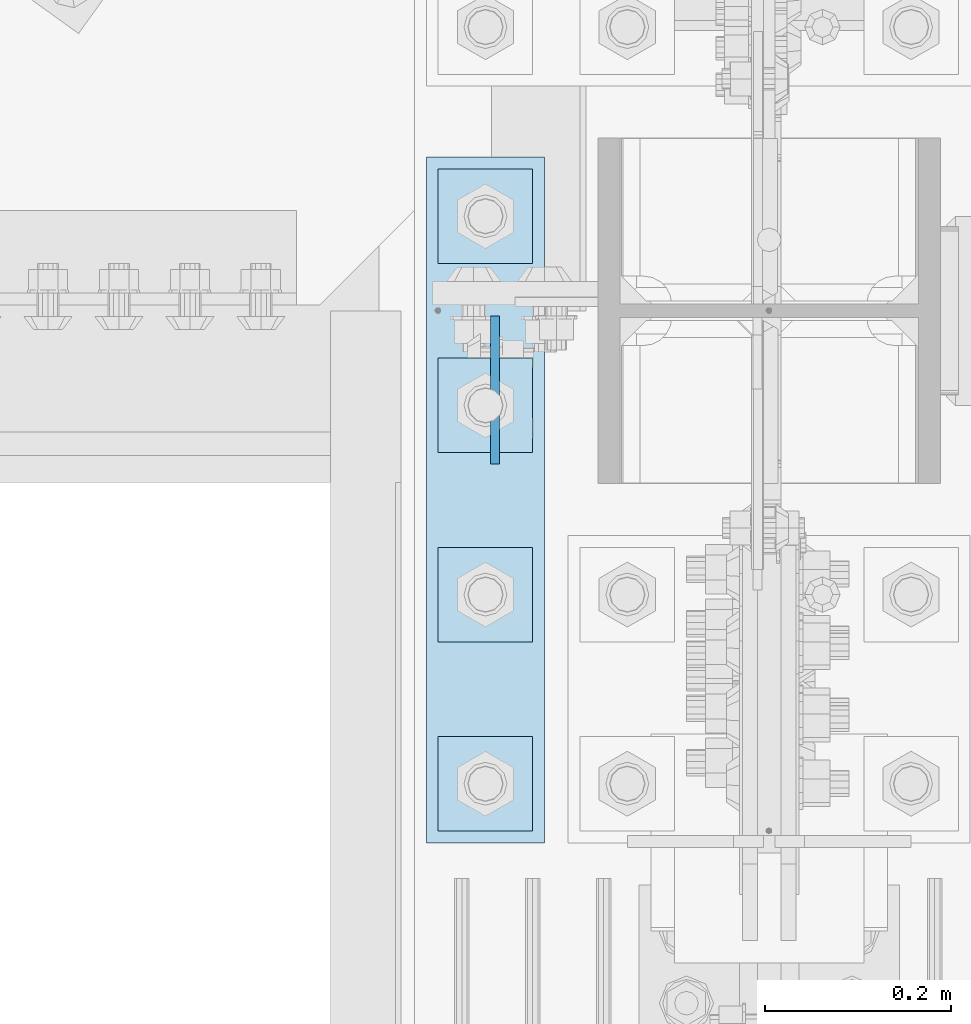
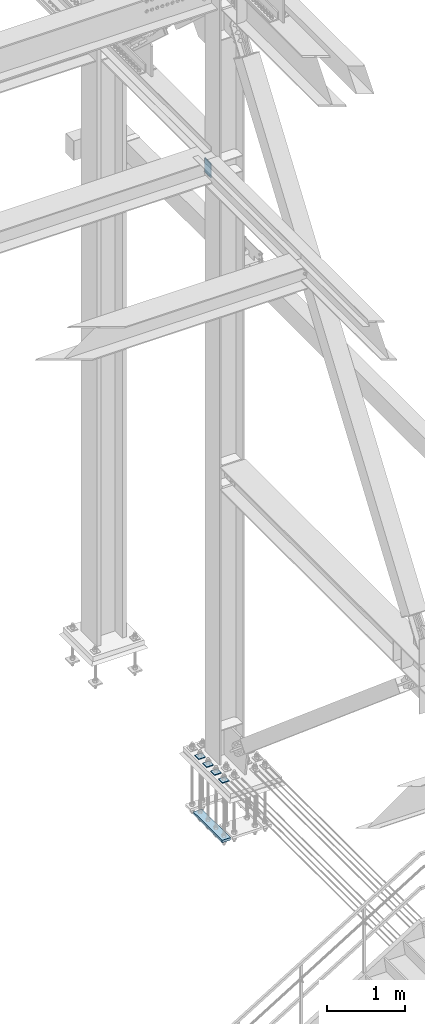
# One storey, part 3576 of 3843: 6 plates, 2 elements without a shape of their own.
"""IFC2X3 building model written with IfcOpenShell, lengths in millimetres."""

from ifc_helpers import new_model, si_unit, frame, origin_with_axes, place, context, subcontext, project, spatial, faceted_brep, material, type_object, element, aggregate, save


model = new_model("IFC2X3")

# Units and contexts
model_context = context("Model", 3, precision=1e-05, world=origin_with_axes())
body_context = subcontext(model_context, "Body", "Model", "MODEL_VIEW")
ifc_project = project(units=[si_unit("LENGTHUNIT", "METRE", prefix="MILLI"), si_unit("AREAUNIT", "SQUARE_METRE"), si_unit("VOLUMEUNIT", "CUBIC_METRE"), si_unit("MASSUNIT", "GRAM", prefix="KILO"), si_unit("TIMEUNIT", "SECOND"), si_unit("PLANEANGLEUNIT", "RADIAN"), si_unit("SOLIDANGLEUNIT", "STERADIAN"), si_unit("THERMODYNAMICTEMPERATUREUNIT", "DEGREE_CELSIUS"), si_unit("LUMINOUSINTENSITYUNIT", "LUMEN")], contexts=[model_context])

# Site, building, storey
site_placement = place(None, origin_with_axes())
site = spatial("IfcSite", under=ifc_project, at=site_placement, CompositionType="ELEMENT")
building_placement = place(site_placement, origin_with_axes())
building = spatial("IfcBuilding", under=site, at=building_placement, Name="Undefined", CompositionType="ELEMENT")
storey_placement = place(building_placement, origin_with_axes())
storey = spatial("IfcBuildingStorey", under=building, at=storey_placement, Name="Undefined", CompositionType="ELEMENT", Elevation=0.0)

# Assembly, plates
assembly_1_placement = place(storey_placement, origin_with_axes())
assembly_1 = element("IfcElementAssembly", 1, at=assembly_1_placement, inside=storey, Name="TEMPLATE", AssemblyPlace="NOTDEFINED", PredefinedType="RIGID_FRAME")
ifc_material = material(Name="STEEL/A572-50")
plate_type_1 = type_object("IfcPlateType", PredefinedType="NOTDEFINED")
plate_1_placement = place(assembly_1_placement, frame((85293.2, 25158.7, 30143.45), z_axis=(0.0, -1.0, 0.0), x_axis=(1.0, 0.0, 0.0)))
plate_1 = element("IfcPlate", 2, at=plate_1_placement, type_object=plate_type_1, material=ifc_material, Name="Washer Plate", context=body_context, shape_type="Brep", body=[
    faceted_brep([(0.0, -6.3499999046162, 0.0), (-1.67347025126219e-10, -6.35000000000582, 101.600000000151), (-1.67347025126219e-10, 6.35000000000582, 101.600000000151), (7.27595761418343e-12, 6.3499999046162, 0.0), (101.599998474121, -6.34999999999854, 101.599998474121), (101.599998474121, 6.34999999999854, 101.599998474121), (101.6, -6.34999999999854, 0.0), (101.6, 6.34999999999854, 0.0)], [[[0, 1, 2, 3]], [[1, 4, 5, 2]], [[4, 6, 7, 5]], [[6, 0, 3, 7]], [[5, 7, 3, 2]], [[6, 4, 1, 0]]]),
])
plate_2_placement = place(assembly_1_placement, frame((85293.2, 25361.9, 30143.45), z_axis=(0.0, -1.0, 0.0), x_axis=(1.0, 0.0, 0.0)))
plate_2 = element("IfcPlate", 3, at=plate_2_placement, type_object=plate_type_1, material=ifc_material, Name="Washer Plate", context=body_context, shape_type="Brep", body=[
    faceted_brep([(0.0, -6.3499999046162, 0.0), (-1.67347025126219e-10, -6.35000000000582, 101.600000000151), (-1.67347025126219e-10, 6.35000000000582, 101.600000000151), (7.27595761418343e-12, 6.3499999046162, 0.0), (101.599998474121, -6.34999999999854, 101.599998474121), (101.599998474121, 6.34999999999854, 101.599998474121), (101.6, -6.34999999999854, 0.0), (101.6, 6.34999999999854, 0.0)], [[[0, 1, 2, 3]], [[1, 4, 5, 2]], [[4, 6, 7, 5]], [[6, 0, 3, 7]], [[5, 7, 3, 2]], [[6, 4, 1, 0]]]),
])
plate_3_placement = place(assembly_1_placement, frame((85293.2, 25565.1, 30143.45), z_axis=(0.0, -1.0, 0.0), x_axis=(1.0, 0.0, 0.0)))
plate_3 = element("IfcPlate", 4, at=plate_3_placement, type_object=plate_type_1, material=ifc_material, Name="Washer Plate", context=body_context, shape_type="Brep", body=[
    faceted_brep([(0.0, -6.3499999046162, 0.0), (-1.67347025126219e-10, -6.35000000000582, 101.600000000151), (-1.67347025126219e-10, 6.35000000000582, 101.600000000151), (7.27595761418343e-12, 6.3499999046162, 0.0), (101.599998474121, -6.34999999999854, 101.599998474121), (101.599998474121, 6.34999999999854, 101.599998474121), (101.6, -6.34999999999854, 0.0), (101.6, 6.34999999999854, 0.0)], [[[0, 1, 2, 3]], [[1, 4, 5, 2]], [[4, 6, 7, 5]], [[6, 0, 3, 7]], [[5, 7, 3, 2]], [[6, 4, 1, 0]]]),
])
plate_4_placement = place(assembly_1_placement, frame((85293.2, 25768.3, 30143.45), z_axis=(0.0, -1.0, 0.0), x_axis=(1.0, 0.0, 0.0)))
plate_4 = element("IfcPlate", 5, at=plate_4_placement, type_object=plate_type_1, material=ifc_material, Name="Washer Plate", context=body_context, shape_type="Brep", body=[
    faceted_brep([(0.0, -6.3499999046162, 0.0), (-1.67347025126219e-10, -6.35000000000582, 101.600000000151), (-1.67347025126219e-10, 6.35000000000582, 101.600000000151), (7.27595761418343e-12, 6.3499999046162, 0.0), (101.599998474121, -6.34999999999854, 101.599998474121), (101.599998474121, 6.34999999999854, 101.599998474121), (101.6, -6.34999999999854, 0.0), (101.6, 6.34999999999854, 0.0)], [[[0, 1, 2, 3]], [[1, 4, 5, 2]], [[4, 6, 7, 5]], [[6, 0, 3, 7]], [[5, 7, 3, 2]], [[6, 4, 1, 0]]]),
])

# Assembly, plate
assembly_2_placement = place(storey_placement, origin_with_axes())
assembly_2 = element("IfcElementAssembly", 6, at=assembly_2_placement, inside=storey, Name="BEAM", AssemblyPlace="NOTDEFINED", PredefinedType="RIGID_FRAME")
plate_type_2 = type_object("IfcPlateType", PredefinedType="NOTDEFINED")
plate_5_placement = place(assembly_2_placement, frame((85354.31875, 25610.34375, 39570.025), z_axis=(0.0, -1.0, 0.0), x_axis=(0.0, 0.0, -1.0)))
plate_5 = element("IfcPlate", 7, at=plate_5_placement, type_object=plate_type_2, material=ifc_material, Name="PLATE", context=body_context, shape_type="Brep", body=[
    faceted_brep([(0.0, -4.76249999999709, 0.0), (0.0, -4.76249999999709, 158.749999526888), (0.0, 4.76249999999709, 158.749999526888), (0.0, 4.76249999999709, 0.0), (228.599999999999, -4.76249999999709, 158.749999526888), (228.599999999999, 4.76249999999709, 158.749999526888), (228.600006103079, -4.7625000004482, 7.27595761418343e-12), (228.600006103079, 4.76249999954598, -7.27595761418343e-12)], [[[0, 1, 2, 3]], [[1, 4, 5, 2]], [[4, 6, 7, 5]], [[6, 0, 3, 7]], [[5, 7, 3, 2]], [[6, 4, 1, 0]]]),
])
aggregate(assembly_2, [plate_5])

# Plate
plate_type_3 = type_object("IfcPlateType", PredefinedType="NOTDEFINED")
plate_6_placement = place(assembly_1_placement, frame((85280.5, 25781.0, 29241.75), z_axis=(0.0, -1.0, 0.0), x_axis=(1.0, 0.0, 0.0)))
plate_6 = element("IfcPlate", 8, at=plate_6_placement, type_object=plate_type_3, material=ifc_material, Name="PLATE", context=body_context, shape_type="Brep", body=[
    faceted_brep([(0.0, -19.0500000000029, 0.0), (0.0, -19.0499999999993, 736.600036621094), (0.0, 19.0499999999993, 736.600036621094), (0.0, 19.0500000000029, 0.0), (127.0, -19.0499999999993, 736.600036621094), (127.0, 19.0499999999993, 736.600036621094), (127.0, -19.0499999999993, 0.0), (127.0, 19.0499999999993, 0.0)], [[[0, 1, 2, 3]], [[1, 4, 5, 2]], [[4, 6, 7, 5]], [[6, 0, 3, 7]], [[5, 7, 3, 2]], [[6, 4, 1, 0]]]),
])

aggregate(assembly_1, [plate_6, plate_1, plate_2, plate_3, plate_4])

save(model, "model.ifc")
